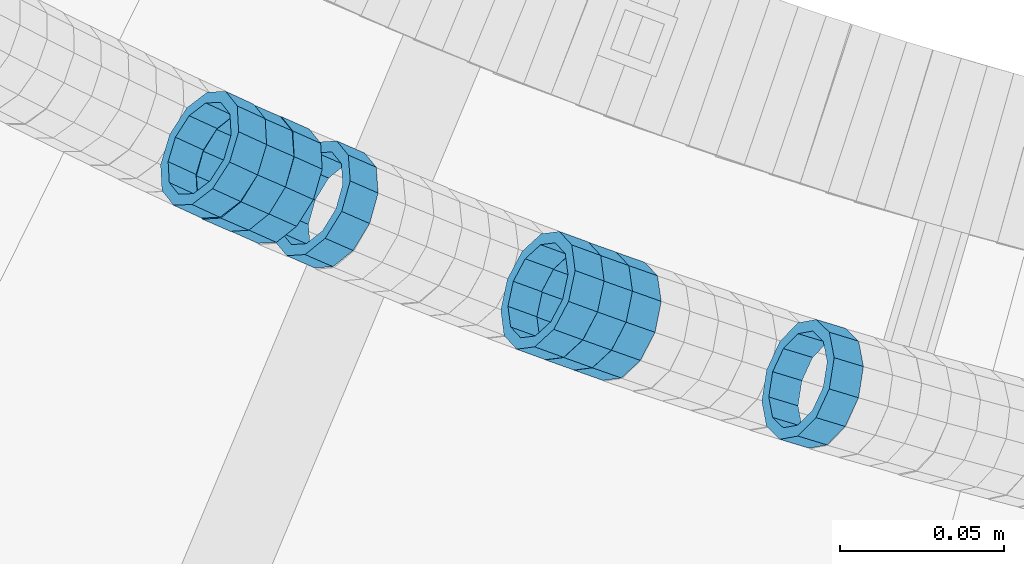
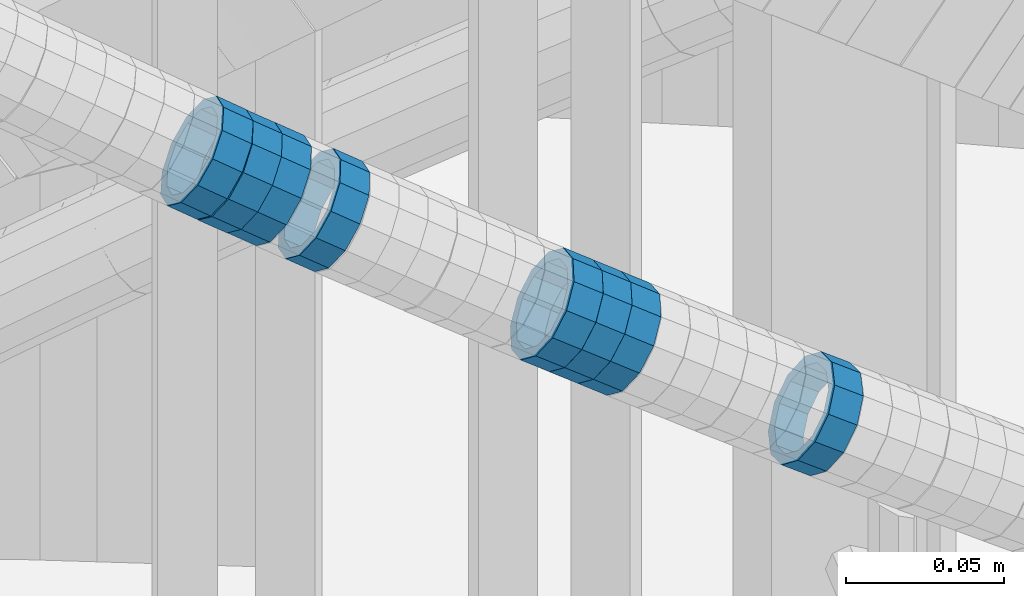
# One storey, part 689 of 975: 8 members.
"""IFC2X3 building model written with IfcOpenShell, lengths in millimetres."""

from ifc_helpers import new_model, si_unit, frame, origin_with_axes, place, context, subcontext, project, spatial, faceted_brep, material, type_object, element, save


model = new_model("IFC2X3")

# Units and contexts
model_context = context("Model", 3, precision=1e-05, world=origin_with_axes())
body_context = subcontext(model_context, "Body", "Model", "MODEL_VIEW")
ifc_project = project(units=[si_unit("LENGTHUNIT", "METRE", prefix="MILLI"), si_unit("AREAUNIT", "SQUARE_METRE"), si_unit("VOLUMEUNIT", "CUBIC_METRE"), si_unit("MASSUNIT", "GRAM", prefix="KILO"), si_unit("TIMEUNIT", "SECOND"), si_unit("PLANEANGLEUNIT", "RADIAN"), si_unit("SOLIDANGLEUNIT", "STERADIAN"), si_unit("THERMODYNAMICTEMPERATUREUNIT", "DEGREE_CELSIUS"), si_unit("LUMINOUSINTENSITYUNIT", "LUMEN")], contexts=[model_context])

# Site, building, storey
site_placement = place(None, origin_with_axes())
site = spatial("IfcSite", under=ifc_project, at=site_placement, CompositionType="ELEMENT")
building_placement = place(site_placement, origin_with_axes())
building = spatial("IfcBuilding", under=site, at=building_placement, Name="Undefined", CompositionType="ELEMENT")
storey_placement = place(building_placement, origin_with_axes())
storey = spatial("IfcBuildingStorey", under=building, at=storey_placement, Name="Undefined", CompositionType="ELEMENT", Elevation=0.0)

# Members
ifc_material = material()
member_type = type_object("IfcMemberType", PredefinedType="NOTDEFINED")
member_1_placement = place(storey_placement, frame((34302.7709214033, 1988.39720824035, 4477.1576898202), z_axis=(-0.290305798469577, -0.95693392842711, -3.87069121643435e-10), x_axis=(-0.815895944453096, 0.247518994137463, 0.522540099290159)))
element("IfcMember", 1, at=member_1_placement, inside=storey, type_object=member_type, material=ifc_material, Name="WALL", context=body_context, shape_type="Brep", body=[
    faceted_brep([(-2.1246523829177e-07, -15.367000000002, 0.0), (-1.83998054126278e-07, -13.3082123799541, 7.68350000000009), (10.9055031979988, -13.3082123799322, 7.68349999999873), (10.9055031979988, -15.3669999999729, -1.81898940354586e-12), (-1.06232619145885e-07, -7.68349999999919, 13.3082123799559), (10.9055031979842, -7.683499999981, 13.3082123799552), (-3.63797880709171e-12, 3.63797880709171e-12, 15.3670000000002), (10.9055031979697, 7.27595761418343e-12, 15.3670000000002), (1.06225343188271e-07, 7.68350000000646, 13.3082123799559), (10.9055031979478, 7.68349999999191, 13.3082123799561), (1.8399441614747e-07, 13.308212379965, 7.68350000000009), (10.9055031979333, 13.3082123799395, 7.68350000000078), (2.12461600312963e-07, 15.3670000000093, 0.0), (10.9055031979187, 15.3669999999802, 4.54747350886464e-13), (1.8399441614747e-07, 13.308212379965, -7.68350000000009), (10.9055031979187, 13.3082123799395, -7.68350000000009), (1.06225343188271e-07, 7.68350000000646, -13.3082123799559), (10.9055031979296, 7.68349999999191, -13.3082123799561), (-3.63797880709171e-12, 3.63797880709171e-12, -15.3670000000002), (10.9055031979478, 3.63797880709171e-12, -15.3670000000013), (-1.06232619145885e-07, -7.68349999999919, -13.3082123799559), (10.9055031979697, -7.683499999981, -13.3082123799575), (-1.83998054126278e-07, -13.3082123799541, -7.68350000000009), (10.9055031979842, -13.3082123799286, -7.68350000000214), (-2.63386027654633e-07, -19.0500000000029, 0.0), (-2.28097633225843e-07, -16.4977839420972, -9.52499999999964), (10.9055031979879, -16.4977839420681, -9.52500000000214), (10.9055031980097, -19.0499999999629, -2.04636307898909e-12), (-1.31691194837913e-07, -9.52500000000146, -16.4977839420935), (10.9055031979624, -9.52499999998327, -16.4977839420956), (-3.63797880709171e-12, 3.63797880709171e-12, -19.0500000000002), (10.9055031979406, 3.63797880709171e-12, -19.0500000000015), (1.31687556859106e-07, 9.52500000000509, -16.4977839420935), (10.9055031979151, 9.5249999999869, -16.4977839420942), (2.28097633225843e-07, 16.4977839421044, -9.52499999999964), (10.9055031979115, 16.4977839420717, -9.52499999999986), (2.63382389675826e-07, 19.0500000000138, 0.0), (10.9055031979115, 19.0499999999774, 6.82121026329696e-13), (2.28097633225843e-07, 16.4977839421044, 9.52499999999964), (10.9055031979296, 16.4977839420753, 9.52500000000123), (1.31687556859106e-07, 9.52500000000509, 16.4977839420935), (10.9055031979515, 9.52499999999054, 16.4977839420942), (-3.63797880709171e-12, 3.63797880709171e-12, 19.0500000000002), (10.9055031979733, 7.27595761418343e-12, 19.0500000000004), (-1.31691194837913e-07, -9.52500000000146, 16.4977839420935), (10.9055031979988, -9.52499999997599, 16.4977839420933), (-2.28097633225843e-07, -16.4977839420972, 9.52499999999964), (10.905503198006, -16.4977839420644, 9.52499999999873)], [[[0, 1, 2, 3]], [[1, 4, 5, 2]], [[4, 6, 7, 5]], [[6, 8, 9, 7]], [[8, 10, 11, 9]], [[10, 12, 13, 11]], [[12, 14, 15, 13]], [[14, 16, 17, 15]], [[16, 18, 19, 17]], [[18, 20, 21, 19]], [[20, 22, 23, 21]], [[22, 0, 3, 23]], [[24, 25, 26, 27]], [[25, 28, 29, 26]], [[28, 30, 31, 29]], [[30, 32, 33, 31]], [[32, 34, 35, 33]], [[34, 36, 37, 35]], [[36, 38, 39, 37]], [[38, 40, 41, 39]], [[40, 42, 43, 41]], [[42, 44, 45, 43]], [[44, 46, 47, 45]], [[46, 24, 27, 47]], [[29, 31, 33, 35, 37, 39, 41, 43, 45, 47, 27, 26], [5, 7, 9, 11, 13, 15, 17, 19, 21, 23, 3, 2]], [[46, 44, 42, 40, 38, 36, 34, 32, 30, 28, 25, 24], [22, 20, 18, 16, 14, 12, 10, 8, 6, 4, 1, 0]]]),
])
member_2_placement = place(storey_placement, frame((34240.9105593934, 2008.74906970603, 4517.32129625374), z_axis=(-0.332259422926545, -0.943188038450721, -1.36165908770636e-10), x_axis=(-0.801026766719983, 0.282179883901396, 0.527949459815544)))
element("IfcMember", 2, at=member_2_placement, inside=storey, type_object=member_type, material=ifc_material, Name="WALL", context=body_context, shape_type="Brep", body=[
    faceted_brep([(-2.1246523829177e-07, -15.367000000002, 0.0), (-1.83998054126278e-07, -13.3082123799541, 7.68350000000009), (10.9927248669192, -13.3082123799686, 7.6835000000026), (10.9927248668937, -15.3670000000238, 5.6843418860808e-12), (-1.06232619145885e-07, -7.68349999999919, 13.3082123799559), (10.9927248669374, -7.68350000000282, 13.3082123799563), (-3.63797880709171e-12, 3.63797880709171e-12, 15.3670000000002), (10.9927248669519, 0.0, 15.3669999999991), (1.06225343188271e-07, 7.68350000000646, 13.3082123799559), (10.9927248669519, 7.68349999999919, 13.3082123799541), (1.8399441614747e-07, 13.308212379965, 7.68350000000009), (10.9927248669446, 13.3082123799504, 7.68349999999964), (2.12461600312963e-07, 15.3670000000093, 0.0), (10.9927248669301, 15.3669999999838, 1.13686837721616e-12), (1.8399441614747e-07, 13.308212379965, -7.68350000000009), (10.9927248669046, 13.3082123799322, -7.68349999999646), (1.06225343188271e-07, 7.68350000000646, -13.3082123799559), (10.9927248668791, 7.68349999996281, -13.3082123799493), (-3.63797880709171e-12, 3.63797880709171e-12, -15.3670000000002), (10.9927248668719, -3.63797880709171e-11, -15.366999999992), (-1.06232619145885e-07, -7.68349999999919, -13.3082123799559), (10.9927248668682, -7.68350000003193, -13.3082123799472), (-1.83998054126278e-07, -13.3082123799541, -7.68350000000009), (10.9927248668791, -13.3082123799832, -7.68349999999282), (-2.63386027654633e-07, -19.0500000000029, 0.0), (-2.28097633225843e-07, -16.4977839420972, -9.52499999999964), (10.9927248668682, -16.4977839421263, -9.52499999999168), (10.9927248668901, -19.0500000000211, 5.6843418860808e-12), (-1.31691194837913e-07, -9.52500000000146, -16.4977839420935), (10.9927248668573, -9.52500000003783, -16.4977839420844), (-3.63797880709171e-12, 3.63797880709171e-12, -19.0500000000002), (10.992724866861, -4.36557456851006e-11, -19.0499999999909), (1.31687556859106e-07, 9.52500000000509, -16.4977839420935), (10.9927248668755, 9.52499999996144, -16.4977839420865), (2.28097633225843e-07, 16.4977839421044, -9.52499999999964), (10.9927248669046, 16.4977839420644, -9.52499999999577), (2.63382389675826e-07, 19.0500000000138, 0.0), (10.9927248669301, 19.0499999999884, 9.09494701772928e-13), (2.28097633225843e-07, 16.4977839421044, 9.52499999999964), (10.9927248669519, 16.4977839420899, 9.52499999999873), (1.31687556859106e-07, 9.52500000000509, 16.4977839420935), (10.9927248669628, 9.52500000000146, 16.497783942091), (-3.63797880709171e-12, 3.63797880709171e-12, 19.0500000000002), (10.9927248669628, 3.63797880709171e-12, 19.0499999999979), (-1.31691194837913e-07, -9.52500000000146, 16.4977839420935), (10.992724866941, -9.52499999999782, 16.4977839420935), (-2.28097633225843e-07, -16.4977839420972, 9.52499999999964), (10.9927248669192, -16.4977839421008, 9.52500000000282)], [[[0, 1, 2, 3]], [[1, 4, 5, 2]], [[4, 6, 7, 5]], [[6, 8, 9, 7]], [[8, 10, 11, 9]], [[10, 12, 13, 11]], [[12, 14, 15, 13]], [[14, 16, 17, 15]], [[16, 18, 19, 17]], [[18, 20, 21, 19]], [[20, 22, 23, 21]], [[22, 0, 3, 23]], [[24, 25, 26, 27]], [[25, 28, 29, 26]], [[28, 30, 31, 29]], [[30, 32, 33, 31]], [[32, 34, 35, 33]], [[34, 36, 37, 35]], [[36, 38, 39, 37]], [[38, 40, 41, 39]], [[40, 42, 43, 41]], [[42, 44, 45, 43]], [[44, 46, 47, 45]], [[46, 24, 27, 47]], [[29, 31, 33, 35, 37, 39, 41, 43, 45, 47, 27, 26], [5, 7, 9, 11, 13, 15, 17, 19, 21, 23, 3, 2]], [[46, 44, 42, 40, 38, 36, 34, 32, 30, 28, 25, 24], [22, 20, 18, 16, 14, 12, 10, 8, 6, 4, 1, 0]]]),
])
member_3_placement = place(storey_placement, frame((34223.5875886537, 2014.99249150311, 4528.72776459276), z_axis=(-0.341743063382724, -0.939793423380794, 1.39732037496287e-10), x_axis=(-0.802757998730859, 0.291911999902096, 0.519968248825622)))
element("IfcMember", 3, at=member_3_placement, inside=storey, type_object=member_type, material=ifc_material, Name="WALL", context=body_context, shape_type="Brep", body=[
    faceted_brep([(-2.1246523829177e-07, -15.367000000002, 0.0), (-1.83998054126278e-07, -13.3082123799541, 7.68350000000009), (10.9608393839299, -13.3082123799613, 7.68350000000282), (10.9608393839189, -15.3670000000093, 3.63797880709171e-12), (-1.06232619145885e-07, -7.68349999999919, 13.3082123799559), (10.9608393839408, -7.68349999999919, 13.3082123799563), (-3.63797880709171e-12, 3.63797880709171e-12, 15.3670000000002), (10.9608393839517, 3.63797880709171e-12, 15.3669999999993), (1.06225343188271e-07, 7.68350000000646, 13.3082123799559), (10.960839383959, 7.68350000000282, 13.3082123799536), (1.8399441614747e-07, 13.308212379965, 7.68350000000009), (10.9608393839553, 13.3082123799577, 7.68349999999782), (2.12461600312963e-07, 15.3670000000093, 0.0), (10.960839383959, 15.367000000002, -2.27373675443232e-12), (1.8399441614747e-07, 13.308212379965, -7.68350000000009), (10.960839383948, 13.3082123799468, -7.68350000000146), (1.06225343188271e-07, 7.68350000000646, -13.3082123799559), (10.9608393839408, 7.68349999998827, -13.3082123799563), (-3.63797880709171e-12, 3.63797880709171e-12, -15.3670000000002), (10.9608393839299, -1.09139364212751e-11, -15.3669999999993), (-1.06232619145885e-07, -7.68349999999919, -13.3082123799559), (10.9608393839226, -7.68350000001374, -13.3082123799531), (-1.83998054126278e-07, -13.3082123799541, -7.68350000000009), (10.9608393839226, -13.308212379965, -7.68349999999691), (-2.63386027654633e-07, -19.0500000000029, 0.0), (-2.28097633225843e-07, -16.4977839420972, -9.52499999999964), (10.9608393839153, -16.4977839421081, -9.52499999999645), (10.9608393839153, -19.0500000000065, 4.09272615797818e-12), (-1.31691194837913e-07, -9.52500000000146, -16.4977839420935), (10.9608393839189, -9.52500000001237, -16.4977839420908), (-3.63797880709171e-12, 3.63797880709171e-12, -19.0500000000002), (10.9608393839262, -1.45519152283669e-11, -19.0499999999984), (1.31687556859106e-07, 9.52500000000509, -16.4977839420935), (10.9608393839371, 9.5249999999869, -16.4977839420935), (2.28097633225843e-07, 16.4977839421044, -9.52499999999964), (10.9608393839553, 16.4977839420899, -9.52500000000282), (2.63382389675826e-07, 19.0500000000138, 0.0), (10.9608393839626, 19.0499999999993, -3.18323145620525e-12), (2.28097633225843e-07, 16.4977839421044, 9.52499999999964), (10.9608393839626, 16.4977839420972, 9.52499999999645), (1.31687556859106e-07, 9.52500000000509, 16.4977839420935), (10.960839383959, 9.52500000000509, 16.4977839420917), (-3.63797880709171e-12, 3.63797880709171e-12, 19.0500000000002), (10.9608393839517, 7.27595761418343e-12, 19.0499999999997), (-1.31691194837913e-07, -9.52500000000146, 16.4977839420935), (10.9608393839408, -9.52499999999782, 16.4977839420944), (-2.28097633225843e-07, -16.4977839420972, 9.52499999999964), (10.9608393839226, -16.4977839420972, 9.52500000000418)], [[[0, 1, 2, 3]], [[1, 4, 5, 2]], [[4, 6, 7, 5]], [[6, 8, 9, 7]], [[8, 10, 11, 9]], [[10, 12, 13, 11]], [[12, 14, 15, 13]], [[14, 16, 17, 15]], [[16, 18, 19, 17]], [[18, 20, 21, 19]], [[20, 22, 23, 21]], [[22, 0, 3, 23]], [[24, 25, 26, 27]], [[25, 28, 29, 26]], [[28, 30, 31, 29]], [[30, 32, 33, 31]], [[32, 34, 35, 33]], [[34, 36, 37, 35]], [[36, 38, 39, 37]], [[38, 40, 41, 39]], [[40, 42, 43, 41]], [[42, 44, 45, 43]], [[44, 46, 47, 45]], [[46, 24, 27, 47]], [[29, 31, 33, 35, 37, 39, 41, 43, 45, 47, 27, 26], [5, 7, 9, 11, 13, 15, 17, 19, 21, 23, 3, 2]], [[46, 44, 42, 40, 38, 36, 34, 32, 30, 28, 25, 24], [22, 20, 18, 16, 14, 12, 10, 8, 6, 4, 1, 0]]]),
])
member_4_placement = place(storey_placement, frame((34232.1720695332, 2011.86556239508, 4523.08879554285), z_axis=(-0.335650407080997, -0.94198662635218, -2.58687578025274e-11), x_axis=(-0.801613535252216, 0.285632409089915, 0.525195075165348)))
element("IfcMember", 4, at=member_4_placement, inside=storey, type_object=member_type, material=ifc_material, Name="WALL", context=body_context, shape_type="Brep", body=[
    faceted_brep([(-2.1246523829177e-07, -15.367000000002, 0.0), (-1.83998054126278e-07, -13.3082123799541, 7.68350000000009), (10.8531101533481, -13.3082123799322, 7.68350000001374), (10.8531101533372, -15.3669999999838, 9.09494701772928e-12), (-1.06232619145885e-07, -7.68349999999919, 13.3082123799559), (10.8531101533517, -7.68349999997736, 13.3082123799686), (-3.63797880709171e-12, 3.63797880709171e-12, 15.3670000000002), (10.8531101533481, 1.45519152283669e-11, 15.3670000000129), (1.06225343188271e-07, 7.68350000000646, 13.3082123799559), (10.8531101533335, 7.68350000000282, 13.3082123799595), (1.8399441614747e-07, 13.308212379965, 7.68350000000009), (10.8531101533117, 13.3082123799468, 7.68349999999373), (2.12461600312963e-07, 15.3670000000093, 0.0), (10.8531101532935, 15.3669999999838, -1.2732925824821e-11), (1.8399441614747e-07, 13.308212379965, -7.68350000000009), (10.853110153279, 13.3082123799322, -7.68350000001737), (1.06225343188271e-07, 7.68350000000646, -13.3082123799559), (10.8531101532717, 7.68349999997736, -13.3082123799741), (-3.63797880709171e-12, 3.63797880709171e-12, -15.3670000000002), (10.853110153279, -1.45519152283669e-11, -15.3670000000166), (-1.06232619145885e-07, -7.68349999999919, -13.3082123799559), (10.8531101532972, -7.68349999999919, -13.3082123799632), (-1.83998054126278e-07, -13.3082123799541, -7.68350000000009), (10.8531101533154, -13.3082123799504, -7.68349999999919), (-2.63386027654633e-07, -19.0500000000029, 0.0), (-2.28097633225843e-07, -16.4977839420972, -9.52499999999964), (10.8531101533154, -16.4977839420826, -9.52499999999782), (10.8531101533408, -19.0499999999774, 1.09139364212751e-11), (-1.31691194837913e-07, -9.52500000000146, -16.4977839420935), (10.8531101532935, -9.52500000000509, -16.4977839421044), (-3.63797880709171e-12, 3.63797880709171e-12, -19.0500000000002), (10.8531101532717, -1.81898940354586e-11, -19.0500000000193), (1.31687556859106e-07, 9.52500000000509, -16.4977839420935), (10.8531101532681, 9.52499999997599, -16.4977839421172), (2.28097633225843e-07, 16.4977839421044, -9.52499999999964), (10.8531101532717, 16.4977839420681, -9.52500000002328), (2.63382389675826e-07, 19.0500000000138, 0.0), (10.8531101532899, 19.0499999999811, -1.63709046319127e-11), (2.28097633225843e-07, 16.4977839421044, 9.52499999999964), (10.8531101533117, 16.4977839420862, 9.52499999999236), (1.31687556859106e-07, 9.52500000000509, 16.4977839420935), (10.8531101533372, 9.52500000000509, 16.497783942099), (-3.63797880709171e-12, 3.63797880709171e-12, 19.0500000000002), (10.853110153359, 1.81898940354586e-11, 19.0500000000156), (-1.31691194837913e-07, -9.52500000000146, 16.4977839420935), (10.853110153359, -9.52499999997963, 16.4977839421099), (-2.28097633225843e-07, -16.4977839420972, 9.52499999999964), (10.853110153359, -16.4977839420681, 9.52500000001783)], [[[0, 1, 2, 3]], [[1, 4, 5, 2]], [[4, 6, 7, 5]], [[6, 8, 9, 7]], [[8, 10, 11, 9]], [[10, 12, 13, 11]], [[12, 14, 15, 13]], [[14, 16, 17, 15]], [[16, 18, 19, 17]], [[18, 20, 21, 19]], [[20, 22, 23, 21]], [[22, 0, 3, 23]], [[24, 25, 26, 27]], [[25, 28, 29, 26]], [[28, 30, 31, 29]], [[30, 32, 33, 31]], [[32, 34, 35, 33]], [[34, 36, 37, 35]], [[36, 38, 39, 37]], [[38, 40, 41, 39]], [[40, 42, 43, 41]], [[42, 44, 45, 43]], [[44, 46, 47, 45]], [[46, 24, 27, 47]], [[29, 31, 33, 35, 37, 39, 41, 43, 45, 47, 27, 26], [5, 7, 9, 11, 13, 15, 17, 19, 21, 23, 3, 2]], [[46, 44, 42, 40, 38, 36, 34, 32, 30, 28, 25, 24], [22, 20, 18, 16, 14, 12, 10, 8, 6, 4, 1, 0]]]),
])
member_5_placement = place(storey_placement, frame((34154.4478962698, 2042.4897743797, 4574.57211996475), z_axis=(-0.399120513127906, -0.916898476386845, -2.28237695409917e-11), x_axis=(-0.781066589676599, 0.339993691859196, 0.523774065783064)))
element("IfcMember", 5, at=member_5_placement, inside=storey, type_object=member_type, material=ifc_material, Name="WALL", context=body_context, shape_type="Brep", body=[
    faceted_brep([(-2.1246523829177e-07, -15.367000000002, 0.0), (-1.83998054126278e-07, -13.3082123799541, 7.68350000000009), (10.8784190028109, -13.3082123799541, 7.68349999999555), (10.8784190028309, -15.3669999999929, 2.5465851649642e-11), (-1.06232619145885e-07, -7.68349999999919, 13.3082123799559), (10.8784190027873, -7.68350000000464, 13.308212379925), (-3.63797880709171e-12, 3.63797880709171e-12, 15.3670000000002), (10.8784190027782, -9.09494701772928e-12, 15.3669999999584), (1.06225343188271e-07, 7.68350000000646, 13.3082123799559), (10.8784190027691, 7.68349999998645, 13.3082123798995), (1.8399441614747e-07, 13.308212379965, 7.68350000000009), (10.8784190027764, 13.3082123799431, 7.68349999995553), (2.12461600312963e-07, 15.3670000000093, 0.0), (10.8784190027891, 15.3669999999929, -2.91038304567337e-11), (1.8399441614747e-07, 13.308212379965, -7.68350000000009), (10.8784190028055, 13.3082123799541, -7.68350000000646), (1.06225343188271e-07, 7.68350000000646, -13.3082123799559), (10.8784190028236, 7.68350000000464, -13.3082123799431), (-3.63797880709171e-12, 3.63797880709171e-12, -15.3670000000002), (10.87841900284, 1.2732925824821e-11, -15.366999999962), (-1.06232619145885e-07, -7.68349999999919, -13.3082123799559), (10.8784190028437, -7.68349999998463, -13.308212379914), (-1.83998054126278e-07, -13.3082123799541, -7.68350000000009), (10.8784190028437, -13.3082123799413, -7.68349999996281), (-2.63386027654633e-07, -19.0500000000029, 0.0), (-2.28097633225843e-07, -16.4977839420972, -9.52499999999964), (10.8784190028491, -16.4977839420771, -9.52499999995416), (10.8784190028346, -19.0499999999902, 2.91038304567337e-11), (-1.31691194837913e-07, -9.52500000000146, -16.4977839420935), (10.8784190028582, -9.52499999998145, -16.497783942039), (-3.63797880709171e-12, 3.63797880709171e-12, -19.0500000000002), (10.8784190028473, 1.63709046319127e-11, -19.0499999999556), (1.31687556859106e-07, 9.52500000000509, -16.4977839420935), (10.8784190028291, 9.52500000000691, -16.4977839420753), (2.28097633225843e-07, 16.4977839421044, -9.52499999999964), (10.8784190028073, 16.4977839420917, -9.52500000000509), (2.63382389675826e-07, 19.0500000000138, 0.0), (10.8784190027836, 19.0499999999884, -4.00177668780088e-11), (2.28097633225843e-07, 16.4977839421044, 9.52499999999964), (10.8784190027654, 16.4977839420771, 9.52499999994325), (1.31687556859106e-07, 9.52500000000509, 16.4977839420935), (10.8784190027636, 9.52499999998327, 16.4977839420317), (-3.63797880709171e-12, 3.63797880709171e-12, 19.0500000000002), (10.8784190027709, -1.63709046319127e-11, 19.0499999999447), (-1.31691194837913e-07, -9.52500000000146, 16.4977839420935), (10.8784190027854, -9.52500000000691, 16.4977839420644), (-2.28097633225843e-07, -16.4977839420972, 9.52499999999964), (10.8784190028091, -16.4977839420899, 9.52500000000146)], [[[0, 1, 2, 3]], [[1, 4, 5, 2]], [[4, 6, 7, 5]], [[6, 8, 9, 7]], [[8, 10, 11, 9]], [[10, 12, 13, 11]], [[12, 14, 15, 13]], [[14, 16, 17, 15]], [[16, 18, 19, 17]], [[18, 20, 21, 19]], [[20, 22, 23, 21]], [[22, 0, 3, 23]], [[24, 25, 26, 27]], [[25, 28, 29, 26]], [[28, 30, 31, 29]], [[30, 32, 33, 31]], [[32, 34, 35, 33]], [[34, 36, 37, 35]], [[36, 38, 39, 37]], [[38, 40, 41, 39]], [[40, 42, 43, 41]], [[42, 44, 45, 43]], [[44, 46, 47, 45]], [[46, 24, 27, 47]], [[29, 31, 33, 35, 37, 39, 41, 43, 45, 47, 27, 26], [5, 7, 9, 11, 13, 15, 17, 19, 21, 23, 3, 2]], [[46, 44, 42, 40, 38, 36, 34, 32, 30, 28, 25, 24], [22, 20, 18, 16, 14, 12, 10, 8, 6, 4, 1, 0]]]),
])
member_6_placement = place(storey_placement, frame((34137.4162642713, 2049.86684183309, 4586.05282757795), z_axis=(-0.408130541313389, -0.912923579083835, 1.542048266856e-10), x_axis=(-0.778605084064914, 0.348082273029016, 0.522123409043516)))
element("IfcMember", 6, at=member_6_placement, inside=storey, type_object=member_type, material=ifc_material, Name="WALL", context=body_context, shape_type="Brep", body=[
    faceted_brep([(-2.1246523829177e-07, -15.367000000002, 0.0), (-1.83998054126278e-07, -13.3082123799541, 7.68350000000009), (10.9242848735521, -13.3082123800159, 7.68350000000919), (10.9242848735703, -15.3670000000457, 6.82121026329696e-12), (-1.06232619145885e-07, -7.68349999999919, 13.3082123799559), (10.9242848735521, -7.68350000005739, 13.3082123799652), (-3.63797880709171e-12, 3.63797880709171e-12, 15.3670000000002), (10.924284873563, -4.72937244921923e-11, 15.3670000000088), (1.06225343188271e-07, 7.68350000000646, 13.3082123799559), (10.9242848735885, 7.68349999997008, 13.308212379962), (1.8399441614747e-07, 13.308212379965, 7.68350000000009), (10.9242848736176, 13.3082123799468, 7.68350000000328), (2.12461600312963e-07, 15.3670000000093, 0.0), (10.9242848736394, 15.3670000000093, 0.0), (1.8399441614747e-07, 13.308212379965, -7.68350000000009), (10.9242848736576, 13.3082123799795, -7.6835000000026), (1.06225343188271e-07, 7.68350000000646, -13.3082123799559), (10.9242848736576, 7.68350000002465, -13.3082123799584), (-3.63797880709171e-12, 3.63797880709171e-12, -15.3670000000002), (10.9242848736467, 1.45519152283669e-11, -15.3670000000025), (-1.06232619145885e-07, -7.68349999999919, -13.3082123799559), (10.9242848736212, -7.68350000000282, -13.3082123799552), (-1.83998054126278e-07, -13.3082123799541, -7.68350000000009), (10.9242848735958, -13.3082123799832, -7.68349999999646), (-2.63386027654633e-07, -19.0500000000029, 0.0), (-2.28097633225843e-07, -16.4977839420972, -9.52499999999964), (10.9242848735885, -16.4977839421226, -9.52499999999577), (10.9242848735557, -19.0500000000575, 8.18545231595635e-12), (-1.31691194837913e-07, -9.52500000000146, -16.4977839420935), (10.9242848736249, -9.52500000000146, -16.4977839420942), (-3.63797880709171e-12, 3.63797880709171e-12, -19.0500000000002), (10.924284873654, 2.18278728425503e-11, -19.0500000000038), (1.31687556859106e-07, 9.52500000000509, -16.4977839420935), (10.9242848736758, 9.52500000003783, -16.4977839420985), (2.28097633225843e-07, 16.4977839421044, -9.52499999999964), (10.9242848736758, 16.4977839421299, -9.52500000000418), (2.63382389675826e-07, 19.0500000000138, 0.0), (10.9242848736503, 19.0500000000211, -1.36424205265939e-12), (2.28097633225843e-07, 16.4977839421044, 9.52499999999964), (10.9242848736249, 16.4977839420899, 9.52500000000259), (1.31687556859106e-07, 9.52500000000509, 16.4977839420935), (10.9242848735885, 9.52499999996508, 16.4977839421008), (-3.63797880709171e-12, 3.63797880709171e-12, 19.0500000000002), (10.9242848735594, -5.82076609134674e-11, 19.0500000000104), (-1.31691194837913e-07, -9.52500000000146, 16.4977839420935), (10.9242848735375, -9.52500000007058, 16.4977839421056), (-2.28097633225843e-07, -16.4977839420972, 9.52499999999964), (10.9242848735412, -16.4977839421626, 9.52500000001078)], [[[0, 1, 2, 3]], [[1, 4, 5, 2]], [[4, 6, 7, 5]], [[6, 8, 9, 7]], [[8, 10, 11, 9]], [[10, 12, 13, 11]], [[12, 14, 15, 13]], [[14, 16, 17, 15]], [[16, 18, 19, 17]], [[18, 20, 21, 19]], [[20, 22, 23, 21]], [[22, 0, 3, 23]], [[24, 25, 26, 27]], [[25, 28, 29, 26]], [[28, 30, 31, 29]], [[30, 32, 33, 31]], [[32, 34, 35, 33]], [[34, 36, 37, 35]], [[36, 38, 39, 37]], [[38, 40, 41, 39]], [[40, 42, 43, 41]], [[42, 44, 45, 43]], [[44, 46, 47, 45]], [[46, 24, 27, 47]], [[29, 31, 33, 35, 37, 39, 41, 43, 45, 47, 27, 26], [5, 7, 9, 11, 13, 15, 17, 19, 21, 23, 3, 2]], [[46, 44, 42, 40, 38, 36, 34, 32, 30, 28, 25, 24], [22, 20, 18, 16, 14, 12, 10, 8, 6, 4, 1, 0]]]),
])
member_7_placement = place(storey_placement, frame((34128.8478962698, 2053.58977437967, 4591.7721199648), z_axis=(-0.399120513127906, -0.916898476386845, -2.28237695409917e-11), x_axis=(-0.781066589676599, 0.339993691859196, 0.523774065783064)))
element("IfcMember", 7, at=member_7_placement, inside=storey, type_object=member_type, material=ifc_material, Name="WALL", context=body_context, shape_type="Brep", body=[
    faceted_brep([(-2.1246523829177e-07, -15.367000000002, 0.0), (-1.83998054126278e-07, -13.3082123799541, 7.68350000000009), (10.8784190028109, -13.3082123799541, 7.68349999999555), (10.8784190028309, -15.3669999999929, 2.5465851649642e-11), (-1.06232619145885e-07, -7.68349999999919, 13.3082123799559), (10.8784190027873, -7.68350000000464, 13.308212379925), (-3.63797880709171e-12, 3.63797880709171e-12, 15.3670000000002), (10.8784190027782, -9.09494701772928e-12, 15.3669999999584), (1.06225343188271e-07, 7.68350000000646, 13.3082123799559), (10.8784190027691, 7.68349999998645, 13.3082123798995), (1.8399441614747e-07, 13.308212379965, 7.68350000000009), (10.8784190027764, 13.3082123799431, 7.68349999995553), (2.12461600312963e-07, 15.3670000000093, 0.0), (10.8784190027891, 15.3669999999929, -2.91038304567337e-11), (1.8399441614747e-07, 13.308212379965, -7.68350000000009), (10.8784190028055, 13.3082123799541, -7.68350000000646), (1.06225343188271e-07, 7.68350000000646, -13.3082123799559), (10.8784190028236, 7.68350000000464, -13.3082123799431), (-3.63797880709171e-12, 3.63797880709171e-12, -15.3670000000002), (10.87841900284, 1.2732925824821e-11, -15.366999999962), (-1.06232619145885e-07, -7.68349999999919, -13.3082123799559), (10.8784190028437, -7.68349999998463, -13.308212379914), (-1.83998054126278e-07, -13.3082123799541, -7.68350000000009), (10.8784190028437, -13.3082123799413, -7.68349999996281), (-2.63386027654633e-07, -19.0500000000029, 0.0), (-2.28097633225843e-07, -16.4977839420972, -9.52499999999964), (10.8784190028491, -16.4977839420771, -9.52499999995416), (10.8784190028346, -19.0499999999902, 2.91038304567337e-11), (-1.31691194837913e-07, -9.52500000000146, -16.4977839420935), (10.8784190028582, -9.52499999998145, -16.497783942039), (-3.63797880709171e-12, 3.63797880709171e-12, -19.0500000000002), (10.8784190028473, 1.63709046319127e-11, -19.0499999999556), (1.31687556859106e-07, 9.52500000000509, -16.4977839420935), (10.8784190028291, 9.52500000000691, -16.4977839420753), (2.28097633225843e-07, 16.4977839421044, -9.52499999999964), (10.8784190028073, 16.4977839420917, -9.52500000000509), (2.63382389675826e-07, 19.0500000000138, 0.0), (10.8784190027836, 19.0499999999884, -4.00177668780088e-11), (2.28097633225843e-07, 16.4977839421044, 9.52499999999964), (10.8784190027654, 16.4977839420771, 9.52499999994325), (1.31687556859106e-07, 9.52500000000509, 16.4977839420935), (10.8784190027636, 9.52499999998327, 16.4977839420317), (-3.63797880709171e-12, 3.63797880709171e-12, 19.0500000000002), (10.8784190027709, -1.63709046319127e-11, 19.0499999999447), (-1.31691194837913e-07, -9.52500000000146, 16.4977839420935), (10.8784190027854, -9.52500000000691, 16.4977839420644), (-2.28097633225843e-07, -16.4977839420972, 9.52499999999964), (10.8784190028091, -16.4977839420899, 9.52500000000146)], [[[0, 1, 2, 3]], [[1, 4, 5, 2]], [[4, 6, 7, 5]], [[6, 8, 9, 7]], [[8, 10, 11, 9]], [[10, 12, 13, 11]], [[12, 14, 15, 13]], [[14, 16, 17, 15]], [[16, 18, 19, 17]], [[18, 20, 21, 19]], [[20, 22, 23, 21]], [[22, 0, 3, 23]], [[24, 25, 26, 27]], [[25, 28, 29, 26]], [[28, 30, 31, 29]], [[30, 32, 33, 31]], [[32, 34, 35, 33]], [[34, 36, 37, 35]], [[36, 38, 39, 37]], [[38, 40, 41, 39]], [[40, 42, 43, 41]], [[42, 44, 45, 43]], [[44, 46, 47, 45]], [[46, 24, 27, 47]], [[29, 31, 33, 35, 37, 39, 41, 43, 45, 47, 27, 26], [5, 7, 9, 11, 13, 15, 17, 19, 21, 23, 3, 2]], [[46, 44, 42, 40, 38, 36, 34, 32, 30, 28, 25, 24], [22, 20, 18, 16, 14, 12, 10, 8, 6, 4, 1, 0]]]),
])
member_8_placement = place(storey_placement, frame((34120.3709369068, 2057.49446673677, 4597.51071593728), z_axis=(-0.41702286780523, -0.908895993900018, -8.39290805743077e-11), x_axis=(-0.772408161781647, 0.354399038899878, 0.527054980851088)))
element("IfcMember", 8, at=member_8_placement, inside=storey, type_object=member_type, material=ifc_material, Name="WALL", context=body_context, shape_type="Brep", body=[
    faceted_brep([(-2.1246523829177e-07, -15.367000000002, 0.0), (-1.83998054126278e-07, -13.3082123799541, 7.68350000000009), (11.0022724925184, -13.3082123799686, 7.6835000000101), (11.0022724925111, -15.3670000000129, 1.45519152283669e-11), (-1.06232619145885e-07, -7.68349999999919, 13.3082123799559), (11.002272492522, -7.6835000000101, 13.308212379965), (-3.63797880709171e-12, 3.63797880709171e-12, 15.3670000000002), (11.0022724925257, -7.27595761418343e-12, 15.3670000000056), (1.06225343188271e-07, 7.68350000000646, 13.3082123799559), (11.0022724925329, 7.68349999999919, 13.3082123799559), (1.8399441614747e-07, 13.308212379965, 7.68350000000009), (11.0022724925329, 13.3082123799577, 7.68349999999919), (2.12461600312963e-07, 15.3670000000093, 0.0), (11.0022724925366, 15.367000000002, -3.63797880709171e-12), (1.8399441614747e-07, 13.308212379965, -7.68350000000009), (11.0022724925329, 13.3082123799577, -7.68350000000464), (1.06225343188271e-07, 7.68350000000646, -13.3082123799559), (11.0022724925366, 7.68350000000282, -13.3082123799577), (-3.63797880709171e-12, 3.63797880709171e-12, -15.3670000000002), (11.0022724925257, -3.63797880709171e-12, -15.3669999999984), (-1.06232619145885e-07, -7.68349999999919, -13.3082123799559), (11.002272492522, -7.68350000000646, -13.3082123799486), (-1.83998054126278e-07, -13.3082123799541, -7.68350000000009), (11.0022724925184, -13.308212379965, -7.68349999999009), (-2.63386027654633e-07, -19.0500000000029, 0.0), (-2.28097633225843e-07, -16.4977839420972, -9.52499999999964), (11.0022724925147, -16.4977839421044, -9.5249999999869), (11.0022724925111, -19.0500000000138, 1.45519152283669e-11), (-1.31691194837913e-07, -9.52500000000146, -16.4977839420935), (11.0022724925184, -9.52500000000873, -16.4977839420881), (-3.63797880709171e-12, 3.63797880709171e-12, -19.0500000000002), (11.0022724925257, -7.27595761418343e-12, -19.0499999999975), (1.31687556859106e-07, 9.52500000000509, -16.4977839420935), (11.0022724925329, 9.52500000000146, -16.4977839420953), (2.28097633225843e-07, 16.4977839421044, -9.52499999999964), (11.0022724925329, 16.4977839420935, -9.52500000000509), (2.63382389675826e-07, 19.0500000000138, 0.0), (11.0022724925366, 19.0500000000029, -5.45696821063757e-12), (2.28097633225843e-07, 16.4977839421044, 9.52499999999964), (11.0022724925366, 16.4977839420972, 9.524999999996), (1.31687556859106e-07, 9.52500000000509, 16.4977839420935), (11.0022724925329, 9.52499999999418, 16.4977839420953), (-3.63797880709171e-12, 3.63797880709171e-12, 19.0500000000002), (11.0022724925293, -3.63797880709171e-12, 19.0500000000047), (-1.31691194837913e-07, -9.52500000000146, 16.4977839420935), (11.002272492522, -9.52500000000873, 16.4977839421026), (-2.28097633225843e-07, -16.4977839420972, 9.52499999999964), (11.0022724925147, -16.4977839421081, 9.52500000001237)], [[[0, 1, 2, 3]], [[1, 4, 5, 2]], [[4, 6, 7, 5]], [[6, 8, 9, 7]], [[8, 10, 11, 9]], [[10, 12, 13, 11]], [[12, 14, 15, 13]], [[14, 16, 17, 15]], [[16, 18, 19, 17]], [[18, 20, 21, 19]], [[20, 22, 23, 21]], [[22, 0, 3, 23]], [[24, 25, 26, 27]], [[25, 28, 29, 26]], [[28, 30, 31, 29]], [[30, 32, 33, 31]], [[32, 34, 35, 33]], [[34, 36, 37, 35]], [[36, 38, 39, 37]], [[38, 40, 41, 39]], [[40, 42, 43, 41]], [[42, 44, 45, 43]], [[44, 46, 47, 45]], [[46, 24, 27, 47]], [[29, 31, 33, 35, 37, 39, 41, 43, 45, 47, 27, 26], [5, 7, 9, 11, 13, 15, 17, 19, 21, 23, 3, 2]], [[46, 44, 42, 40, 38, 36, 34, 32, 30, 28, 25, 24], [22, 20, 18, 16, 14, 12, 10, 8, 6, 4, 1, 0]]]),
])

save(model, "model.ifc")
